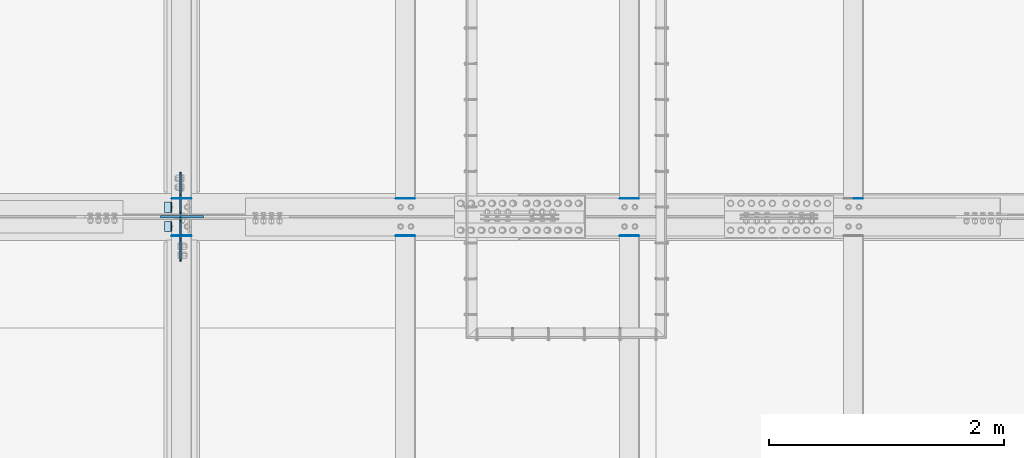
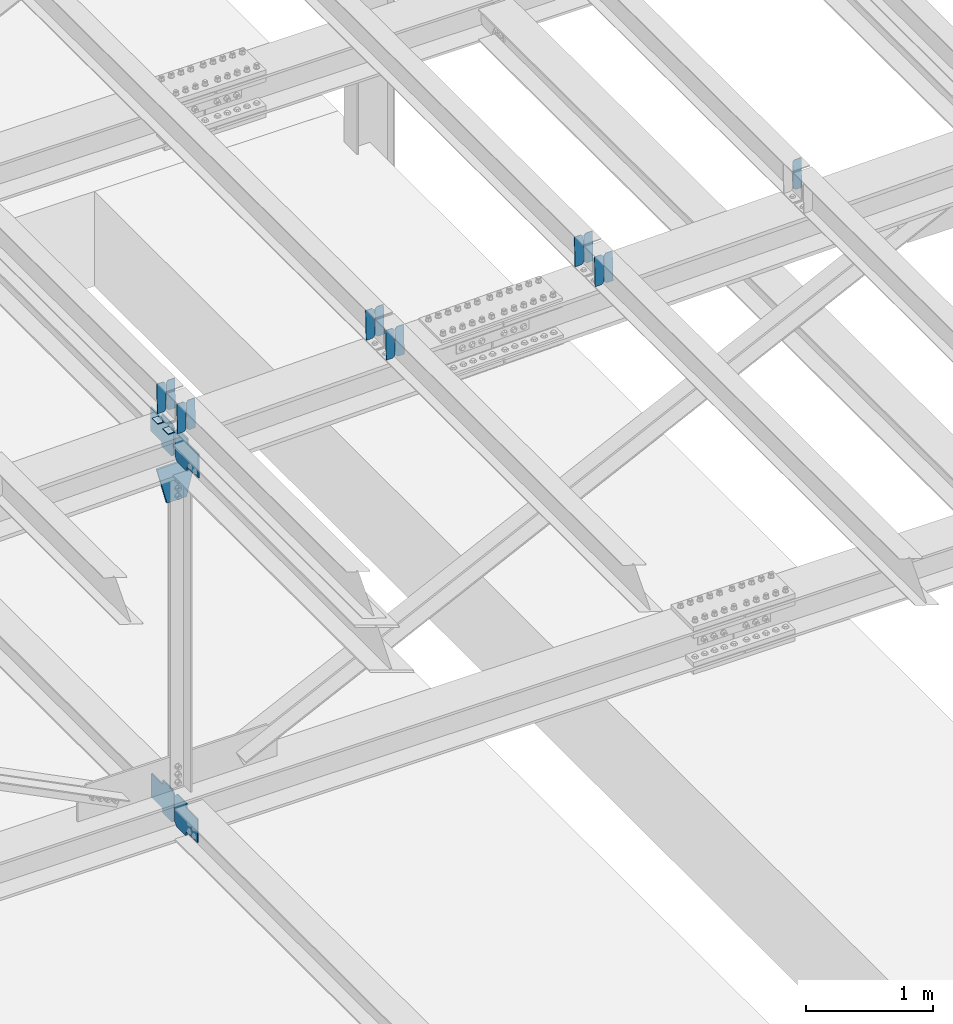
# One storey, part 3442 of 3843: 20 plates, 9 elements without a shape of their own.
"""IFC2X3 building model written with IfcOpenShell, lengths in millimetres."""

from ifc_helpers import new_model, si_unit, frame, origin_with_axes, place, context, subcontext, project, spatial, faceted_brep, material, type_object, element, aggregate, save


model = new_model("IFC2X3")

# Units and contexts
model_context = context("Model", 3, precision=1e-05, world=origin_with_axes())
body_context = subcontext(model_context, "Body", "Model", "MODEL_VIEW")
ifc_project = project(units=[si_unit("LENGTHUNIT", "METRE", prefix="MILLI"), si_unit("AREAUNIT", "SQUARE_METRE"), si_unit("VOLUMEUNIT", "CUBIC_METRE"), si_unit("MASSUNIT", "GRAM", prefix="KILO"), si_unit("TIMEUNIT", "SECOND"), si_unit("PLANEANGLEUNIT", "RADIAN"), si_unit("SOLIDANGLEUNIT", "STERADIAN"), si_unit("THERMODYNAMICTEMPERATUREUNIT", "DEGREE_CELSIUS"), si_unit("LUMINOUSINTENSITYUNIT", "LUMEN")], contexts=[model_context])

# Site, building, storey
site_placement = place(None, origin_with_axes())
site = spatial("IfcSite", under=ifc_project, at=site_placement, CompositionType="ELEMENT")
building_placement = place(site_placement, origin_with_axes())
building = spatial("IfcBuilding", under=site, at=building_placement, Name="Undefined", CompositionType="ELEMENT")
storey_placement = place(building_placement, origin_with_axes())
storey = spatial("IfcBuildingStorey", under=building, at=storey_placement, Name="Undefined", CompositionType="ELEMENT", Elevation=0.0)

# Assembly, plates
assembly_1_placement = place(storey_placement, origin_with_axes())
assembly_1 = element("IfcElementAssembly", 1, at=assembly_1_placement, inside=storey, Name="BEAM", AssemblyPlace="NOTDEFINED", PredefinedType="RIGID_FRAME")
ifc_material = material(Name="STEEL/A572-50")
plate_type_1 = type_object("IfcPlateType", PredefinedType="NOTDEFINED")
plate_1_placement = place(assembly_1_placement, frame((62718.6964783486, 67426.9164516353, 46076.7755783296), z_axis=(-0.0211520980329588, 0.00187065200053622, 0.999774519284172), x_axis=(-0.999776269352655, -3.88860000349027e-05, -0.021152062007432)))
plate_1 = element("IfcPlate", 2, at=plate_1_placement, type_object=plate_type_1, material=ifc_material, Name="PLATE", context=body_context, shape_type="Brep", body=[
    faceted_brep([(0.0, -3.17499999999927, 0.0), (6.83940015733242e-10, -3.17499999996653, 288.924999998613), (6.54836185276508e-10, 3.17500000001746, 288.924999998591), (0.0, 3.17499999999927, 0.0), (60.3250007643655, -3.17500000017753, 288.924999998606), (60.3250007643219, 3.17499999979918, 288.924999998584), (79.3750000013097, -3.17500000025029, 269.875000761494), (79.375000001266, 3.17499999972642, 269.875000761487), (79.375000000713, -3.17500000026484, 19.0499992370605), (79.3750000006985, 3.17499999971187, 19.0499992370533), (60.325000763667, -3.17500000020664, -1.45519152283669e-11), (60.3250007636234, 3.17499999977736, -3.63797880709171e-11)], [[[0, 1, 2, 3]], [[1, 4, 5, 2]], [[4, 6, 7, 5]], [[6, 8, 9, 7]], [[8, 10, 11, 9]], [[10, 0, 3, 11]], [[5, 7, 9, 11, 3, 2]], [[10, 8, 6, 4, 1, 0]]]),
])
plate_2_placement = place(assembly_1_placement, frame((62632.990657659, 67426.9130588929, 46074.9623179021), z_axis=(-0.0211520980329588, 0.00187065200053622, 0.999774519284172), x_axis=(-0.999776269352655, -3.88860000349027e-05, -0.021152062007432)))
plate_2 = element("IfcPlate", 3, at=plate_2_placement, type_object=plate_type_1, material=ifc_material, Name="PLATE", context=body_context, shape_type="Brep", body=[
    faceted_brep([(4.36557456851006e-11, -3.17499999998836, 19.0499992370969), (6.11180439591408e-10, -3.17499999996653, 269.875000761516), (5.96628524363041e-10, 3.17500000001746, 269.875000761502), (1.45519152283669e-11, 3.17499999998836, 19.0499992370824), (19.0499992376572, -3.17500000003201, 288.924999998606), (19.0499992376281, 3.1749999999447, 288.924999998584), (79.3750000013242, -3.17500000025029, 288.924999998591), (79.3750000013097, 3.1749999997337, 288.92499999857), (79.3750000006548, -3.17500000026484, -2.18278728425503e-11), (79.3750000006403, 3.17499999969732, -2.91038304567337e-11), (19.0499992370023, -3.17500000005384, 0.0), (19.0499992369587, 3.17499999992287, -1.45519152283669e-11)], [[[0, 1, 2, 3]], [[1, 4, 5, 2]], [[4, 6, 7, 5]], [[6, 8, 9, 7]], [[8, 10, 11, 9]], [[10, 0, 3, 11]], [[5, 7, 9, 11, 3, 2]], [[10, 8, 6, 4, 1, 0]]]),
])

assembly_2_placement = place(storey_placement, origin_with_axes())
assembly_2 = element("IfcElementAssembly", 4, at=assembly_2_placement, inside=storey, Name="BEAM", AssemblyPlace="NOTDEFINED", PredefinedType="RIGID_FRAME")
plate_3_placement = place(assembly_2_placement, frame((62718.6964783439, 67109.8627903262, 46077.1265870463), z_axis=(-0.0211520975052917, 0.000376250999834155, 0.999776198559614), x_axis=(-0.9997762693548, -8.33599996866193e-06, -0.0211520960075009)))
plate_3 = element("IfcPlate", 5, at=plate_3_placement, type_object=plate_type_1, material=ifc_material, Name="PLATE", context=body_context, shape_type="Brep", body=[
    faceted_brep([(0.0, -3.17499999999927, 0.0), (6.83940015733242e-10, -3.17499999996653, 288.924999998613), (6.54836185276508e-10, 3.17500000001746, 288.924999998591), (0.0, 3.17499999999927, 0.0), (60.3250007643655, -3.17500000017753, 288.924999998606), (60.3250007643219, 3.17499999979918, 288.924999998584), (79.3750000013097, -3.17500000025029, 269.875000761494), (79.375000001266, 3.17499999972642, 269.875000761487), (79.375000000713, -3.17500000026484, 19.0499992370605), (79.3750000006985, 3.17499999971187, 19.0499992370533), (60.325000763667, -3.17500000020664, -1.45519152283669e-11), (60.3250007636234, 3.17499999977736, -3.63797880709171e-11)], [[[0, 1, 2, 3]], [[1, 4, 5, 2]], [[4, 6, 7, 5]], [[6, 8, 9, 7]], [[8, 10, 11, 9]], [[10, 0, 3, 11]], [[5, 7, 9, 11, 3, 2]], [[10, 8, 6, 4, 1, 0]]]),
])
plate_4_placement = place(assembly_2_placement, frame((62632.9906576542, 67109.8621079315, 46075.3133235744), z_axis=(-0.0211520975052917, 0.000376250999834155, 0.999776198559614), x_axis=(-0.9997762693548, -8.33599996866193e-06, -0.0211520960075009)))
plate_4 = element("IfcPlate", 6, at=plate_4_placement, type_object=plate_type_1, material=ifc_material, Name="PLATE", context=body_context, shape_type="Brep", body=[
    faceted_brep([(4.36557456851006e-11, -3.17499999998836, 19.0499992370969), (6.11180439591408e-10, -3.17499999996653, 269.875000761516), (5.96628524363041e-10, 3.17500000001746, 269.875000761502), (1.45519152283669e-11, 3.17499999998836, 19.0499992370824), (19.0499992376572, -3.17500000003201, 288.924999998606), (19.0499992376281, 3.1749999999447, 288.924999998584), (79.3750000013242, -3.17500000025029, 288.924999998591), (79.3750000013097, 3.1749999997337, 288.92499999857), (79.3750000006548, -3.17500000026484, -2.18278728425503e-11), (79.3750000006403, 3.17499999969732, -2.91038304567337e-11), (19.0499992370023, -3.17500000005384, 0.0), (19.0499992369587, 3.17499999992287, -1.45519152283669e-11)], [[[0, 1, 2, 3]], [[1, 4, 5, 2]], [[4, 6, 7, 5]], [[6, 8, 9, 7]], [[8, 10, 11, 9]], [[10, 0, 3, 11]], [[5, 7, 9, 11, 3, 2]], [[10, 8, 6, 4, 1, 0]]]),
])

# Assembly, plate
assembly_3_placement = place(storey_placement, origin_with_axes())
assembly_3 = element("IfcElementAssembly", 7, at=assembly_3_placement, inside=storey, Name="BEAM", AssemblyPlace="NOTDEFINED", PredefinedType="RIGID_FRAME")
plate_5_placement = place(assembly_3_placement, frame((68433.6966631243, 67426.8625905448, 46201.0813634709), z_axis=(-0.0211520984965173, 0.00205084399976477, 0.999774165883517), x_axis=(-0.999776269341419, -4.278700010456e-05, -0.0211520550071887)))
plate_5 = element("IfcPlate", 8, at=plate_5_placement, type_object=plate_type_1, material=ifc_material, Name="PLATE", context=body_context, shape_type="Brep", body=[
    faceted_brep([(0.0, -3.17499999999927, 0.0), (6.83940015733242e-10, -3.17499999996653, 288.924999998613), (6.54836185276508e-10, 3.17500000001746, 288.924999998591), (0.0, 3.17499999999927, 0.0), (60.3250007643655, -3.17500000017753, 288.924999998606), (60.3250007643219, 3.17499999979918, 288.924999998584), (79.3750000013097, -3.17500000025029, 269.875000761494), (79.375000001266, 3.17499999972642, 269.875000761487), (79.375000000713, -3.17500000026484, 19.0499992370605), (79.3750000006985, 3.17499999971187, 19.0499992370533), (60.325000763667, -3.17500000020664, -1.45519152283669e-11), (60.3250007636234, 3.17499999977736, -3.63797880709171e-11)], [[[0, 1, 2, 3]], [[1, 4, 5, 2]], [[4, 6, 7, 5]], [[6, 8, 9, 7]], [[8, 10, 11, 9]], [[10, 0, 3, 11]], [[5, 7, 9, 11, 3, 2]], [[10, 8, 6, 4, 1, 0]]]),
])
aggregate(assembly_3, [plate_5])

# Assembly, plates
assembly_4_placement = place(storey_placement, origin_with_axes())
assembly_4 = element("IfcElementAssembly", 9, at=assembly_4_placement, inside=storey, Name="BEAM", AssemblyPlace="NOTDEFINED", PredefinedType="RIGID_FRAME")
plate_6_placement = place(assembly_4_placement, frame((66528.6966587263, 67426.8747460965, 46160.3384129784), z_axis=(-0.0211520978066692, 0.00201018800094608, 0.999774248469412), x_axis=(-0.999776269341419, -4.278700010456e-05, -0.0211520550071887)))
plate_6 = element("IfcPlate", 10, at=plate_6_placement, type_object=plate_type_1, material=ifc_material, Name="PLATE", context=body_context, shape_type="Brep", body=[
    faceted_brep([(0.0, -3.17499999999927, 0.0), (6.83940015733242e-10, -3.17499999996653, 288.924999998613), (6.54836185276508e-10, 3.17500000001746, 288.924999998591), (0.0, 3.17499999999927, 0.0), (60.3250007643655, -3.17500000017753, 288.924999998606), (60.3250007643219, 3.17499999979918, 288.924999998584), (79.3750000013097, -3.17500000025029, 269.875000761494), (79.375000001266, 3.17499999972642, 269.875000761487), (79.375000000713, -3.17500000026484, 19.0499992370605), (79.3750000006985, 3.17499999971187, 19.0499992370533), (60.325000763667, -3.17500000020664, -1.45519152283669e-11), (60.3250007636234, 3.17499999977736, -3.63797880709171e-11)], [[[0, 1, 2, 3]], [[1, 4, 5, 2]], [[4, 6, 7, 5]], [[6, 8, 9, 7]], [[8, 10, 11, 9]], [[10, 0, 3, 11]], [[5, 7, 9, 11, 3, 2]], [[10, 8, 6, 4, 1, 0]]]),
])
plate_7_placement = place(assembly_4_placement, frame((66442.9908380361, 67426.8710983927, 46158.5251530452), z_axis=(-0.0211520978066692, 0.00201018800094608, 0.999774248469412), x_axis=(-0.999776269341419, -4.278700010456e-05, -0.0211520550071887)))
plate_7 = element("IfcPlate", 11, at=plate_7_placement, type_object=plate_type_1, material=ifc_material, Name="PLATE", context=body_context, shape_type="Brep", body=[
    faceted_brep([(4.36557456851006e-11, -3.17499999998836, 19.0499992370969), (6.11180439591408e-10, -3.17499999996653, 269.875000761516), (5.96628524363041e-10, 3.17500000001746, 269.875000761502), (1.45519152283669e-11, 3.17499999998836, 19.0499992370824), (19.0499992376572, -3.17500000003201, 288.924999998606), (19.0499992376281, 3.1749999999447, 288.924999998584), (79.3750000013242, -3.17500000025029, 288.924999998591), (79.3750000013097, 3.1749999997337, 288.92499999857), (79.3750000006548, -3.17500000026484, -2.18278728425503e-11), (79.3750000006403, 3.17499999969732, -2.91038304567337e-11), (19.0499992370023, -3.17500000005384, 0.0), (19.0499992369587, 3.17499999992287, -1.45519152283669e-11)], [[[0, 1, 2, 3]], [[1, 4, 5, 2]], [[4, 6, 7, 5]], [[6, 8, 9, 7]], [[8, 10, 11, 9]], [[10, 0, 3, 11]], [[5, 7, 9, 11, 3, 2]], [[10, 8, 6, 4, 1, 0]]]),
])
aggregate(assembly_4, [plate_6, plate_7])

assembly_5_placement = place(storey_placement, origin_with_axes())
assembly_5 = element("IfcElementAssembly", 12, at=assembly_5_placement, inside=storey, Name="BEAM", AssemblyPlace="NOTDEFINED", PredefinedType="RIGID_FRAME")
plate_8_placement = place(assembly_5_placement, frame((66528.6966586327, 67109.8498639953, 46160.7179966274), z_axis=(-0.0211520978608897, 0.000419598000124098, 0.999776181299395), x_axis=(-0.9997762693548, -8.33599996866193e-06, -0.0211520960075009)))
plate_8 = element("IfcPlate", 13, at=plate_8_placement, type_object=plate_type_1, material=ifc_material, Name="PLATE", context=body_context, shape_type="Brep", body=[
    faceted_brep([(0.0, -3.17499999999927, 0.0), (6.83940015733242e-10, -3.17499999996653, 288.924999998613), (6.54836185276508e-10, 3.17500000001746, 288.924999998591), (0.0, 3.17499999999927, 0.0), (60.3250007643655, -3.17500000017753, 288.924999998606), (60.3250007643219, 3.17499999979918, 288.924999998584), (79.3750000013097, -3.17500000025029, 269.875000761494), (79.375000001266, 3.17499999972642, 269.875000761487), (79.375000000713, -3.17500000026484, 19.0499992370605), (79.3750000006985, 3.17499999971187, 19.0499992370533), (60.325000763667, -3.17500000020664, -1.45519152283669e-11), (60.3250007636234, 3.17499999977736, -3.63797880709171e-11)], [[[0, 1, 2, 3]], [[1, 4, 5, 2]], [[4, 6, 7, 5]], [[6, 8, 9, 7]], [[8, 10, 11, 9]], [[10, 0, 3, 11]], [[5, 7, 9, 11, 3, 2]], [[10, 8, 6, 4, 1, 0]]]),
])
plate_9_placement = place(assembly_5_placement, frame((66442.9908379414, 67109.8491048698, 46158.9047331849), z_axis=(-0.0211520978608897, 0.000419598000124098, 0.999776181299395), x_axis=(-0.9997762693548, -8.33599996866193e-06, -0.0211520960075009)))
plate_9 = element("IfcPlate", 14, at=plate_9_placement, type_object=plate_type_1, material=ifc_material, Name="PLATE", context=body_context, shape_type="Brep", body=[
    faceted_brep([(4.36557456851006e-11, -3.17499999998836, 19.0499992370969), (6.11180439591408e-10, -3.17499999996653, 269.875000761516), (5.96628524363041e-10, 3.17500000001746, 269.875000761502), (1.45519152283669e-11, 3.17499999998836, 19.0499992370824), (19.0499992376572, -3.17500000003201, 288.924999998606), (19.0499992376281, 3.1749999999447, 288.924999998584), (79.3750000013242, -3.17500000025029, 288.924999998591), (79.3750000013097, 3.1749999997337, 288.92499999857), (79.3750000006548, -3.17500000026484, -2.18278728425503e-11), (79.3750000006403, 3.17499999969732, -2.91038304567337e-11), (19.0499992370023, -3.17500000005384, 0.0), (19.0499992369587, 3.17499999992287, -1.45519152283669e-11)], [[[0, 1, 2, 3]], [[1, 4, 5, 2]], [[4, 6, 7, 5]], [[6, 8, 9, 7]], [[8, 10, 11, 9]], [[10, 0, 3, 11]], [[5, 7, 9, 11, 3, 2]], [[10, 8, 6, 4, 1, 0]]]),
])
aggregate(assembly_5, [plate_8, plate_9])

assembly_6_placement = place(storey_placement, origin_with_axes())
assembly_6 = element("IfcElementAssembly", 15, at=assembly_6_placement, inside=storey, Name="BEAM", AssemblyPlace="NOTDEFINED", PredefinedType="RIGID_FRAME")
plate_10_placement = place(assembly_6_placement, frame((64623.6966630444, 67426.8957183831, 46118.9082343958), z_axis=(-0.0211520978190965, 0.00194001800016849, 0.999774387093413), x_axis=(-0.999776269338344, -4.08370000134752e-05, -0.0211520590071558)))
plate_10 = element("IfcPlate", 16, at=plate_10_placement, type_object=plate_type_1, material=ifc_material, Name="PLATE", context=body_context, shape_type="Brep", body=[
    faceted_brep([(0.0, -3.17499999999927, 0.0), (6.83940015733242e-10, -3.17499999996653, 288.924999998613), (6.54836185276508e-10, 3.17500000001746, 288.924999998591), (0.0, 3.17499999999927, 0.0), (60.3250007643655, -3.17500000017753, 288.924999998606), (60.3250007643219, 3.17499999979918, 288.924999998584), (79.3750000013097, -3.17500000025029, 269.875000761494), (79.375000001266, 3.17499999972642, 269.875000761487), (79.375000000713, -3.17500000026484, 19.0499992370605), (79.3750000006985, 3.17499999971187, 19.0499992370533), (60.325000763667, -3.17500000020664, -1.45519152283669e-11), (60.3250007636234, 3.17499999977736, -3.63797880709171e-11)], [[[0, 1, 2, 3]], [[1, 4, 5, 2]], [[4, 6, 7, 5]], [[6, 8, 9, 7]], [[8, 10, 11, 9]], [[10, 0, 3, 11]], [[5, 7, 9, 11, 3, 2]], [[10, 8, 6, 4, 1, 0]]]),
])
plate_11_placement = place(assembly_6_placement, frame((64537.9908423548, 67426.8922003468, 46117.0949742073), z_axis=(-0.0211520978190965, 0.00194001800016849, 0.999774387093413), x_axis=(-0.999776269338344, -4.08370000134752e-05, -0.0211520590071558)))
plate_11 = element("IfcPlate", 17, at=plate_11_placement, type_object=plate_type_1, material=ifc_material, Name="PLATE", context=body_context, shape_type="Brep", body=[
    faceted_brep([(4.36557456851006e-11, -3.17499999998836, 19.0499992370969), (6.11180439591408e-10, -3.17499999996653, 269.875000761516), (5.96628524363041e-10, 3.17500000001746, 269.875000761502), (1.45519152283669e-11, 3.17499999998836, 19.0499992370824), (19.0499992376572, -3.17500000003201, 288.924999998606), (19.0499992376281, 3.1749999999447, 288.924999998584), (79.3750000013242, -3.17500000025029, 288.924999998591), (79.3750000013097, 3.1749999997337, 288.92499999857), (79.3750000006548, -3.17500000026484, -2.18278728425503e-11), (79.3750000006403, 3.17499999969732, -2.91038304567337e-11), (19.0499992370023, -3.17500000005384, 0.0), (19.0499992369587, 3.17499999992287, -1.45519152283669e-11)], [[[0, 1, 2, 3]], [[1, 4, 5, 2]], [[4, 6, 7, 5]], [[6, 8, 9, 7]], [[8, 10, 11, 9]], [[10, 0, 3, 11]], [[5, 7, 9, 11, 3, 2]], [[10, 8, 6, 4, 1, 0]]]),
])
aggregate(assembly_6, [plate_10, plate_11])

assembly_7_placement = place(storey_placement, origin_with_axes())
assembly_7 = element("IfcElementAssembly", 18, at=assembly_7_placement, inside=storey, Name="BEAM", AssemblyPlace="NOTDEFINED", PredefinedType="RIGID_FRAME")
plate_12_placement = place(assembly_7_placement, frame((64623.696658643, 67109.8560052051, 46119.2736423863), z_axis=(-0.0211520976833125, 0.000399000999888811, 0.999776189735382), x_axis=(-0.9997762693548, -8.33599996866193e-06, -0.0211520960075009)))
plate_12 = element("IfcPlate", 19, at=plate_12_placement, type_object=plate_type_1, material=ifc_material, Name="PLATE", context=body_context, shape_type="Brep", body=[
    faceted_brep([(0.0, -3.17499999999927, 0.0), (6.83940015733242e-10, -3.17499999996653, 288.924999998613), (6.54836185276508e-10, 3.17500000001746, 288.924999998591), (0.0, 3.17499999999927, 0.0), (60.3250007643655, -3.17500000017753, 288.924999998606), (60.3250007643219, 3.17499999979918, 288.924999998584), (79.3750000013097, -3.17500000025029, 269.875000761494), (79.375000001266, 3.17499999972642, 269.875000761487), (79.375000000713, -3.17500000026484, 19.0499992370605), (79.3750000006985, 3.17499999971187, 19.0499992370533), (60.325000763667, -3.17500000020664, -1.45519152283669e-11), (60.3250007636234, 3.17499999977736, -3.63797880709171e-11)], [[[0, 1, 2, 3]], [[1, 4, 5, 2]], [[4, 6, 7, 5]], [[6, 8, 9, 7]], [[8, 10, 11, 9]], [[10, 0, 3, 11]], [[5, 7, 9, 11, 3, 2]], [[10, 8, 6, 4, 1, 0]]]),
])
plate_13_placement = place(assembly_7_placement, frame((64537.9908379537, 67109.8552834352, 46117.4603789289), z_axis=(-0.0211520976833125, 0.000399000999888811, 0.999776189735382), x_axis=(-0.9997762693548, -8.33599996866193e-06, -0.0211520960075009)))
plate_13 = element("IfcPlate", 20, at=plate_13_placement, type_object=plate_type_1, material=ifc_material, Name="PLATE", context=body_context, shape_type="Brep", body=[
    faceted_brep([(4.36557456851006e-11, -3.17499999998836, 19.0499992370969), (6.11180439591408e-10, -3.17499999996653, 269.875000761516), (5.96628524363041e-10, 3.17500000001746, 269.875000761502), (1.45519152283669e-11, 3.17499999998836, 19.0499992370824), (19.0499992376572, -3.17500000003201, 288.924999998606), (19.0499992376281, 3.1749999999447, 288.924999998584), (79.3750000013242, -3.17500000025029, 288.924999998591), (79.3750000013097, 3.1749999997337, 288.92499999857), (79.3750000006548, -3.17500000026484, -2.18278728425503e-11), (79.3750000006403, 3.17499999969732, -2.91038304567337e-11), (19.0499992370023, -3.17500000005384, 0.0), (19.0499992369587, 3.17499999992287, -1.45519152283669e-11)], [[[0, 1, 2, 3]], [[1, 4, 5, 2]], [[4, 6, 7, 5]], [[6, 8, 9, 7]], [[8, 10, 11, 9]], [[10, 0, 3, 11]], [[5, 7, 9, 11, 3, 2]], [[10, 8, 6, 4, 1, 0]]]),
])
aggregate(assembly_7, [plate_12, plate_13])

# Plate
plate_type_2 = type_object("IfcPlateType", PredefinedType="NOTDEFINED")
plate_14_placement = place(assembly_1_placement, frame((62553.7677264489, 67398.8999999999, 46067.2250874765), z_axis=(0.0, -1.0, 0.0), x_axis=(-0.999776270257024, 0.0, -0.0211520550054595)))
plate_14 = element("IfcPlate", 21, at=plate_14_placement, type_object=plate_type_2, material=ifc_material, Name="PLATE", context=body_context, shape_type="Brep", body=[
    faceted_brep([(9.52499999982683, -4.7625000001135, 88.8999999999942), (0.0, 4.76249999999709, 88.9000015258789), (0.0, 4.76249999999709, 0.0), (9.52499999981956, -4.76249999999709, 0.0), (63.4999984608512, -4.76249999988795, 88.8999999999796), (63.4999984608367, -4.76249999988795, -1.45519152283669e-11), (63.4999984608221, 4.76250000013533, -1.45519152283669e-11), (63.4999984608367, 4.76250000013533, 88.8999999999796)], [[[0, 1, 2, 3]], [[4, 5, 6, 7]], [[5, 4, 0, 3]], [[6, 5, 3, 2]], [[7, 6, 2, 1]], [[4, 7, 1, 0]]]),
])

aggregate(assembly_1, [plate_1, plate_2, plate_14])

plate_15_placement = place(assembly_2_placement, frame((62553.7677264489, 67233.8000015258, 46067.2250874765), z_axis=(0.0, -1.0, 0.0), x_axis=(-0.999776270257024, 0.0, -0.0211520550054595)))
plate_15 = element("IfcPlate", 22, at=plate_15_placement, type_object=plate_type_2, material=ifc_material, Name="PLATE", context=body_context, shape_type="Brep", body=[
    faceted_brep([(9.52499999982683, -4.7625000001135, 88.8999999999942), (0.0, 4.76249999999709, 88.9000015258789), (0.0, 4.76249999999709, 0.0), (9.52499999981956, -4.76249999999709, 0.0), (63.4999984608512, -4.76249999988795, 88.8999999999796), (63.4999984608367, -4.76249999988795, -1.45519152283669e-11), (63.4999984608221, 4.76250000013533, -1.45519152283669e-11), (63.4999984608367, 4.76250000013533, 88.8999999999796)], [[[0, 1, 2, 3]], [[4, 5, 6, 7]], [[5, 4, 0, 3]], [[6, 5, 3, 2]], [[7, 6, 2, 1]], [[4, 7, 1, 0]]]),
])

aggregate(assembly_2, [plate_3, plate_4, plate_15])

# Assembly, plates
assembly_8_placement = place(storey_placement, origin_with_axes())
assembly_8 = element("IfcElementAssembly", 23, at=assembly_8_placement, inside=storey, Name="BEAM", AssemblyPlace="NOTDEFINED", PredefinedType="RIGID_FRAME")
plate_type_3 = type_object("IfcPlateType", PredefinedType="NOTDEFINED")
plate_16_placement = place(assembly_8_placement, frame((62625.2874998852, 67264.7562499859, 42214.0054035182), z_axis=(0.0, -0.707106781186682, 0.707106781186413), x_axis=(0.0, -0.707106781186548, -0.707106781186548)))
plate_16 = element("IfcPlate", 24, at=plate_16_placement, type_object=plate_type_3, material=ifc_material, Name="PLATE", context=body_context, shape_type="Brep", body=[
    faceted_brep([(0.0, -6.3499999046162, 0.0), (-179.595012862977, -6.34999999999854, 179.595012862916), (-179.595012862977, 6.34999999999854, 179.595012862916), (7.27595761418343e-12, 6.3499999046162, 0.0), (-179.595012862512, -6.34999999999854, 224.496293468517), (-179.595012862512, 6.34999999999854, 224.496293468517), (-75.7608014709986, -6.34999999999854, 328.330504860052), (-75.7608014709986, 6.34999999999854, 328.330504860052), (-53.3881115789263, -6.34999999999854, 305.957814967987), (-53.3881115789263, 6.34999999999854, 305.957814967987), (-49.2679351107799, -6.34999999999854, 303.204801067528), (-49.2679351107799, 6.34999999999854, 303.204801067528), (-44.4078555927263, -6.34999999999854, 302.238071144959), (-44.4078555927263, 6.34999999999854, 302.238071144959), (-39.547776074658, -6.34999999999854, 303.204801067575), (-39.547776074658, 6.34999999999854, 303.204801067575), (-35.4275996064825, -6.34999999999854, 305.957814968082), (-35.4275996064825, 6.34999999999854, 305.957814968082), (81.3157301141619, -6.34999999999854, 422.701144688755), (81.3157301141619, 6.34999999999854, 422.701144688755), (242.960340292644, -6.34999999999854, 261.05653451031), (242.960340292644, 6.34999999999854, 261.05653451031), (126.217010572014, -6.34999999999854, 144.313204789651), (126.217010572014, 6.34999999999854, 144.313204789651), (123.463996671504, -6.34999999999854, 140.193028321457), (123.463996671504, 6.34999999999854, 140.193028321457), (122.497266748906, -6.34999999999854, 135.3329488034), (122.497266748906, 6.34999999999854, 135.3329488034), (123.463996671446, -6.34999999999854, 130.472869285339), (123.463996671446, 6.34999999999854, 130.472869285339), (126.217010571927, -6.34999999999854, 126.3526928172), (126.217010571927, 6.34999999999854, 126.3526928172), (148.735492004496, -6.35000000000582, 103.834211399357), (148.735492004496, 6.35000000000582, 103.834211399357), (44.9012806051323, -6.35000000000582, -1.45519152283669e-11), (44.9012806051323, 6.35000000000582, -1.45519152283669e-11)], [[[0, 1, 2, 3]], [[1, 4, 5, 2]], [[4, 6, 7, 5]], [[6, 8, 9, 7]], [[8, 10, 11, 9]], [[10, 12, 13, 11]], [[12, 14, 15, 13]], [[14, 16, 17, 15]], [[16, 18, 19, 17]], [[18, 20, 21, 19]], [[20, 22, 23, 21]], [[22, 24, 25, 23]], [[24, 26, 27, 25]], [[26, 28, 29, 27]], [[28, 30, 31, 29]], [[30, 32, 33, 31]], [[32, 34, 35, 33]], [[34, 0, 3, 35]], [[5, 7, 9, 11, 13, 15, 17, 19, 21, 23, 25, 27, 29, 31, 33, 35, 3, 2]], [[34, 32, 30, 28, 26, 24, 22, 20, 18, 16, 14, 12, 10, 8, 6, 4, 1, 0]]]),
])
plate_17_placement = place(assembly_8_placement, frame((62625.287499821, 67279.0437499999, 42214.0054033942), z_axis=(0.0, 0.707106781186548, 0.707106781186548), x_axis=(5.70000238222118e-08, 0.707106781186546, -0.707106781186546)))
plate_17 = element("IfcPlate", 25, at=plate_17_placement, type_object=plate_type_3, material=ifc_material, Name="PLATE", context=body_context, shape_type="Brep", body=[
    faceted_brep([(0.0, -6.3499999046162, 0.0), (-179.595012862977, -6.34999999999854, 179.595012862916), (-179.595012862977, 6.34999999999854, 179.595012862916), (7.27595761418343e-12, 6.3499999046162, 0.0), (-179.595012862512, -6.34999999999854, 224.496293468517), (-179.595012862512, 6.34999999999854, 224.496293468517), (-75.7608014709986, -6.34999999999854, 328.330504860052), (-75.7608014709986, 6.34999999999854, 328.330504860052), (-52.9998777270048, -6.34999999999854, 305.569581136166), (-52.9998777270048, 6.34999999999854, 305.569581136166), (-48.8797012588584, -6.34999999999854, 302.816567235714), (-48.8797012588584, 6.34999999999854, 302.816567235714), (-44.0196217408084, -6.34999999999854, 301.849837313144), (-44.0196217408084, 6.34999999999854, 301.849837313144), (-39.1595422227329, -6.34999999999854, 302.816567235757), (-39.1595422227329, 6.34999999999854, 302.816567235757), (-35.0393657545537, -6.34999999999854, 305.569581136253), (-35.0393657545537, 6.34999999999854, 305.569581136253), (81.7039639560935, -6.34999999999854, 422.3129108469), (81.7039639560935, 6.34999999999854, 422.3129108469), (243.348574134547, -6.34999999999854, 260.668300668403), (243.348574134547, 6.34999999999854, 260.668300668403), (126.605244423896, -6.34999999999854, 143.924970957771), (126.605244423896, 6.34999999999854, 143.924970957771), (123.852230523389, -6.34999999999854, 139.804794489595), (123.852230523389, 6.34999999999854, 139.804794489595), (122.885500600769, -6.34999999999854, 134.944714971527), (122.885500600769, 6.34999999999854, 134.944714971527), (123.852230523335, -6.34999999999854, 130.084635453473), (123.852230523335, 6.34999999999854, 130.084635453473), (126.605244423801, -6.34999999999854, 125.964458985312), (126.605244423801, 6.34999999999854, 125.964458985312), (148.735492004496, -6.35000000000582, 103.834211399357), (148.735492004496, 6.35000000000582, 103.834211399357), (44.9012806051323, -6.35000000000582, -1.45519152283669e-11), (44.9012806051323, 6.35000000000582, -1.45519152283669e-11)], [[[0, 1, 2, 3]], [[1, 4, 5, 2]], [[4, 6, 7, 5]], [[6, 8, 9, 7]], [[8, 10, 11, 9]], [[10, 12, 13, 11]], [[12, 14, 15, 13]], [[14, 16, 17, 15]], [[16, 18, 19, 17]], [[18, 20, 21, 19]], [[20, 22, 23, 21]], [[22, 24, 25, 23]], [[24, 26, 27, 25]], [[26, 28, 29, 27]], [[28, 30, 31, 29]], [[30, 32, 33, 31]], [[32, 34, 35, 33]], [[34, 0, 3, 35]], [[5, 7, 9, 11, 13, 15, 17, 19, 21, 23, 25, 27, 29, 31, 33, 35, 3, 2]], [[34, 32, 30, 28, 26, 24, 22, 20, 18, 16, 14, 12, 10, 8, 6, 4, 1, 0]]]),
])
aggregate(assembly_8, [plate_16, plate_17])

assembly_9_placement = place(storey_placement, origin_with_axes())
assembly_9 = element("IfcElementAssembly", 26, at=assembly_9_placement, inside=storey, Name="BEAM", AssemblyPlace="NOTDEFINED", PredefinedType="RIGID_FRAME")
plate_18_placement = place(assembly_9_placement, frame((62625.2874999632, 67283.012500003, 45740.1624590289), z_axis=(0.0, 0.707106781186548, 0.707106781186548), x_axis=(5.70000238222118e-08, 0.707106781186546, -0.707106781186546)))
plate_18 = element("IfcPlate", 27, at=plate_18_placement, type_object=plate_type_3, material=ifc_material, Name="PLATE", context=body_context, shape_type="Brep", body=[
    faceted_brep([(0.0, -6.3499999046162, 0.0), (-179.461821812436, -6.34999999999854, 179.461821812467), (-179.461821812436, 6.34999999999854, 179.461821812467), (7.27595761418343e-12, 6.3499999046162, 0.0), (-179.461821811959, -6.34999999999854, 224.363102418065), (-179.461821811959, 6.34999999999854, 224.363102418065), (-68.3311523045104, -6.34999999999854, 335.493771925481), (-68.3311523045104, 6.34999999999854, 335.493771925481), (-45.7890500320882, -6.34999999999854, 312.951669653077), (-45.7890500320882, 6.34999999999854, 312.951669653077), (-41.6688735639345, -6.34999999999854, 310.198655752611), (-41.6688735639345, 6.34999999999854, 310.198655752611), (-36.8087940458809, -6.34999999999854, 309.231925830041), (-36.8087940458809, 6.34999999999854, 309.231925830041), (-31.9487145278199, -6.34999999999854, 310.198655752654), (-31.9487145278199, 6.34999999999854, 310.198655752654), (-27.8285380596371, -6.34999999999854, 312.951669653165), (-27.8285380596371, 6.34999999999854, 312.951669653165), (88.9147916435959, -6.34999999999854, 429.694999356361), (88.9147916435959, 6.34999999999854, 429.694999356361), (250.559401822045, -6.34999999999854, 268.050389177879), (250.559401822045, 6.34999999999854, 268.050389177879), (133.816072118812, -6.34999999999854, 151.307059474668), (133.816072118812, 6.34999999999854, 151.307059474668), (131.063058218309, -6.34999999999854, 147.186883006492), (131.063058218309, 6.34999999999854, 147.186883006492), (130.096328295689, -6.34999999999854, 142.326803488424), (130.096328295689, 6.34999999999854, 142.326803488424), (131.063058218258, -6.34999999999854, 137.46672397037), (131.063058218258, 6.34999999999854, 137.46672397037), (133.816072118714, -6.34999999999854, 133.346547502224), (133.816072118714, 6.34999999999854, 133.346547502224), (156.031950102829, -6.35000000000582, 111.130669497703), (156.031950102829, 6.35000000000582, 111.130669497703), (44.9012806051323, -6.35000000000582, -1.45519152283669e-11), (44.9012806051323, 6.35000000000582, -1.45519152283669e-11)], [[[0, 1, 2, 3]], [[1, 4, 5, 2]], [[4, 6, 7, 5]], [[6, 8, 9, 7]], [[8, 10, 11, 9]], [[10, 12, 13, 11]], [[12, 14, 15, 13]], [[14, 16, 17, 15]], [[16, 18, 19, 17]], [[18, 20, 21, 19]], [[20, 22, 23, 21]], [[22, 24, 25, 23]], [[24, 26, 27, 25]], [[26, 28, 29, 27]], [[28, 30, 31, 29]], [[30, 32, 33, 31]], [[32, 34, 35, 33]], [[34, 0, 3, 35]], [[5, 7, 9, 11, 13, 15, 17, 19, 21, 23, 25, 27, 29, 31, 33, 35, 3, 2]], [[34, 32, 30, 28, 26, 24, 22, 20, 18, 16, 14, 12, 10, 8, 6, 4, 1, 0]]]),
])
plate_19_placement = place(assembly_9_placement, frame((62625.2875706015, 67260.7874999322, 45740.1624606967), z_axis=(0.0, -0.707106781186682, 0.707106781186413), x_axis=(0.0, -0.707106781186548, -0.707106781186548)))
plate_19 = element("IfcPlate", 28, at=plate_19_placement, type_object=plate_type_3, material=ifc_material, Name="PLATE", context=body_context, shape_type="Brep", body=[
    faceted_brep([(0.0, -6.3499999046162, 0.0), (-179.461821812436, -6.34999999999854, 179.461821812467), (-179.461821812436, 6.34999999999854, 179.461821812467), (7.27595761418343e-12, 6.3499999046162, 0.0), (-179.461821811959, -6.34999999999854, 224.363102418065), (-179.461821811959, 6.34999999999854, 224.363102418065), (-68.3311523045104, -6.34999999999854, 335.493771925481), (-68.3311523045104, 6.34999999999854, 335.493771925481), (-46.1967264283157, -6.34999999999854, 313.359345978308), (-46.1967264283157, 6.34999999999854, 313.359345978308), (-42.0765499601548, -6.34999999999854, 310.606332077823), (-42.0765499601548, 6.34999999999854, 310.606332077823), (-37.216470442072, -6.34999999999854, 309.639602155268), (-37.216470442072, 6.34999999999854, 309.639602155268), (-32.3563909240038, -6.34999999999854, 310.606332077892), (-32.3563909240038, 6.34999999999854, 310.606332077892), (-28.2362144558283, -6.34999999999854, 313.359345978424), (-28.2362144558283, 6.34999999999854, 313.359345978424), (88.5071152798482, -6.34999999999854, 430.102675715072), (88.5071152798482, 6.34999999999854, 430.102675715072), (250.151725459, -6.34999999999854, 268.458065535608), (250.151725459, 6.34999999999854, 268.458065535608), (133.408395723221, -6.34999999999854, 151.714735798865), (133.408395723221, 6.34999999999854, 151.714735798865), (130.655381822726, -6.34999999999854, 147.59455933069), (130.655381822726, 6.34999999999854, 147.59455933069), (129.688651900142, -6.34999999999854, 142.73447981264), (129.688651900142, 6.34999999999854, 142.73447981264), (130.655381822711, -6.34999999999854, 137.874400294611), (130.655381822711, 6.34999999999854, 137.874400294611), (133.408395723149, -6.34999999999854, 133.754223826465), (133.408395723149, 6.34999999999854, 133.754223826465), (156.031950102829, -6.35000000000582, 111.130669497703), (156.031950102829, 6.35000000000582, 111.130669497703), (44.9012806051323, -6.35000000000582, -1.45519152283669e-11), (44.9012806051323, 6.35000000000582, -1.45519152283669e-11)], [[[0, 1, 2, 3]], [[1, 4, 5, 2]], [[4, 6, 7, 5]], [[6, 8, 9, 7]], [[8, 10, 11, 9]], [[10, 12, 13, 11]], [[12, 14, 15, 13]], [[14, 16, 17, 15]], [[16, 18, 19, 17]], [[18, 20, 21, 19]], [[20, 22, 23, 21]], [[22, 24, 25, 23]], [[24, 26, 27, 25]], [[26, 28, 29, 27]], [[28, 30, 31, 29]], [[30, 32, 33, 31]], [[32, 34, 35, 33]], [[34, 0, 3, 35]], [[5, 7, 9, 11, 13, 15, 17, 19, 21, 23, 25, 27, 29, 31, 33, 35, 3, 2]], [[34, 32, 30, 28, 26, 24, 22, 20, 18, 16, 14, 12, 10, 8, 6, 4, 1, 0]]]),
])
plate_type_4 = type_object("IfcPlateType", PredefinedType="NOTDEFINED")
plate_20_placement = place(assembly_9_placement, frame((62818.8204871662, 67271.9, 45674.3844397658), z_axis=(0.0222946239995654, 0.0, -0.999751443980312), x_axis=(-0.999751443980311, 0.0, -0.0222946239995679)))
plate_20 = element("IfcPlate", 29, at=plate_20_placement, type_object=plate_type_4, material=ifc_material, Name="PLATE", context=body_context, shape_type="Brep", body=[
    faceted_brep([(0.0, -9.52500000000146, 0.0), (101.556466922477, -9.52499999999418, 359.312527673363), (101.556466922477, 9.52499999999418, 359.312527673363), (0.0, 9.52500000000146, 0.0), (279.312274681448, -9.52499999999418, 355.348543305321), (279.312274681448, 9.52499999999418, 355.348543305321), (363.274325362261, -9.52499999999418, 1.17870513349771e-09), (363.274325362261, 9.52499999999418, 1.17870513349771e-09)], [[[0, 1, 2, 3]], [[1, 4, 5, 2]], [[4, 6, 7, 5]], [[6, 0, 3, 7]], [[5, 7, 3, 2]], [[6, 4, 1, 0]]]),
])
aggregate(assembly_9, [plate_18, plate_19, plate_20])

save(model, "model.ifc")
